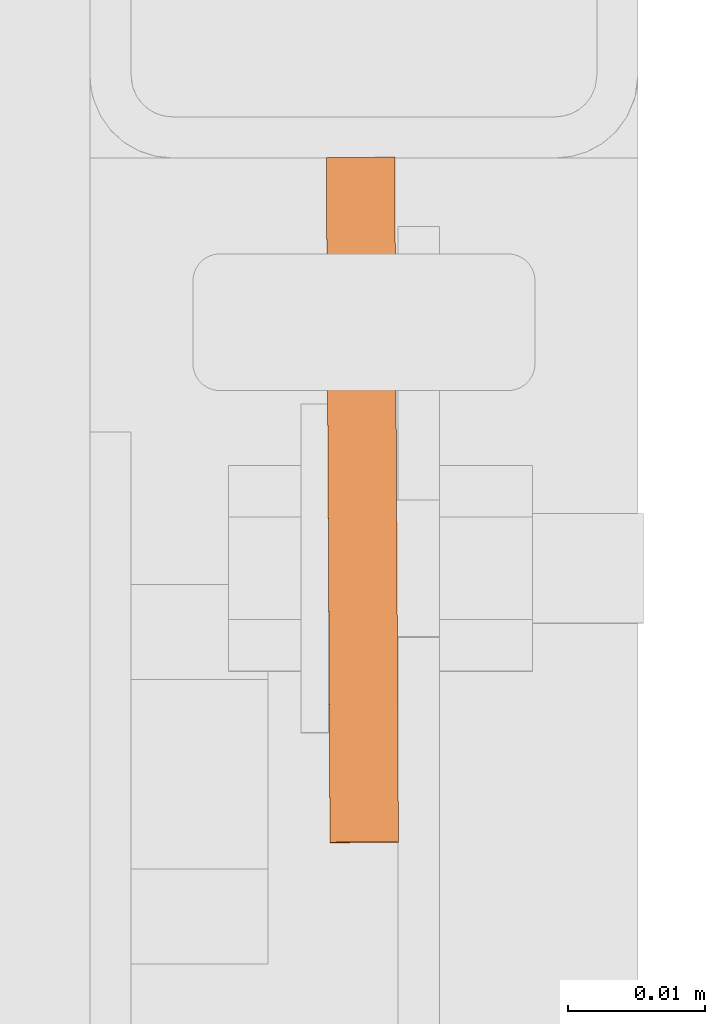
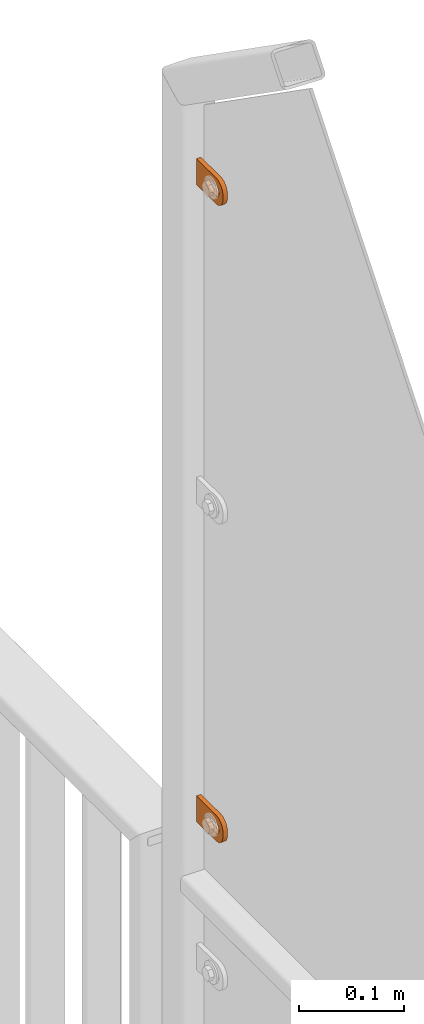
# One storey, part 148 of 156: 2 proxies, 1 element without a shape of its own.
"""IFC2X3 building model written with IfcOpenShell, lengths in millimetres."""

import ifcopenshell
import ifcopenshell.guid

model = None  # the IFC model being written
_history = None  # IfcOwnerHistory: only IFC2X3 demands one
_inside = {}  # id of a spatial element -> (the spatial element, [elements in it])
_under = {}  # id of a project, library or spatial element -> (it, [spatial elements below it])
_declared = {}  # id of a project -> (the project, [libraries it declares])
_typed = {}  # id of a type object -> (the type object, [elements of that type])
_made_of = {}  # id of a material, layer set ... -> (it, [elements and type objects made of it])


def new_model(schema):
    """Start an empty IFC model of exactly this schema.

    Asked for "IFC4X3", IfcOpenShell would pick the latest addendum, in which some entities
    have other attributes; the version numbers below select the first issue.
    IFC2X3 requires an IfcOwnerHistory on every rooted entity: one is made here for all.
    """
    global model, _history
    if schema == "IFC4X3":
        model = ifcopenshell.file(schema_version=(4, 3, 0, 0))
    else:
        model = ifcopenshell.file(schema=schema)
    _inside.clear()
    _under.clear()
    _declared.clear()
    _typed.clear()
    _made_of.clear()
    _history = None
    if model.schema == "IFC2X3":
        org = make("IfcOrganization", Name="unknown")
        user = make(
            "IfcPersonAndOrganization",
            ThePerson=make("IfcPerson", FamilyName="unknown"),
            TheOrganization=org,
        )
        app = make(
            "IfcApplication",
            ApplicationDeveloper=org,
            Version="unknown",
            ApplicationFullName="unknown",
            ApplicationIdentifier="unknown",
        )
        _history = make(
            "IfcOwnerHistory",
            OwningUser=user,
            OwningApplication=app,
            ChangeAction="ADDED",
            CreationDate=0,
        )
    return model


def make(cls, **values):
    """One entity of the class cls with the attributes given. An attribute that is None is left unset."""
    return model.create_entity(
        cls, **{name: value for name, value in values.items() if value is not None}
    )


def rooted(cls, **values):
    """An entity with a GlobalId (a new one), such as an element, a storey or a relation."""
    return make(cls, GlobalId=ifcopenshell.guid.new(), OwnerHistory=_history, **values)


def si_unit(unit_type, name, prefix=None):
    """IfcSIUnit, for example si_unit("LENGTHUNIT", "METRE", prefix="MILLI")."""
    return make("IfcSIUnit", UnitType=unit_type, Prefix=prefix, Name=name)


def assignment(units):
    """IfcUnitAssignment: the units of a project."""
    return None if units is None else make("IfcUnitAssignment", Units=units)


def point(xyz):
    """IfcCartesianPoint."""
    return None if xyz is None else make("IfcCartesianPoint", Coordinates=xyz)


def direction(xyz):
    """IfcDirection."""
    return None if xyz is None else make("IfcDirection", DirectionRatios=xyz)


def frame(location, z_axis=None, x_axis=None):
    """IfcAxis2Placement3D, a coordinate frame: its origin and axes. An axis left out is left unset."""
    return make(
        "IfcAxis2Placement3D",
        Location=point(location),
        Axis=direction(z_axis),
        RefDirection=direction(x_axis),
    )


def origin_with_axes():
    """The frame at (0, 0, 0) with the z axis (0, 0, 1) and the x axis (1, 0, 0) written out."""
    return frame((0.0, 0.0, 0.0), z_axis=(0.0, 0.0, 1.0), x_axis=(1.0, 0.0, 0.0))


def place(relative_to, where):
    """IfcLocalPlacement: puts the frame where relative to a parent placement (None: the world)."""
    return make(
        "IfcLocalPlacement", PlacementRelTo=relative_to, RelativePlacement=where
    )


def context(
    kind, dimensions, precision=None, world=None, true_north=None, identifier=None
):
    """IfcGeometricRepresentationContext, for example the 3D "Model" context."""
    return make(
        "IfcGeometricRepresentationContext",
        ContextIdentifier=identifier,
        ContextType=kind,
        CoordinateSpaceDimension=dimensions,
        Precision=precision,
        WorldCoordinateSystem=world,
        TrueNorth=true_north,
    )


def subcontext(parent, identifier, kind, view, scale=None):
    """IfcGeometricRepresentationSubContext, for example "Body" below "Model"."""
    return make(
        "IfcGeometricRepresentationSubContext",
        ContextIdentifier=identifier,
        ContextType=kind,
        ParentContext=parent,
        TargetScale=scale,
        TargetView=view,
    )


def project(units=None, contexts=None):
    """IfcProject with its units and contexts."""
    return rooted(
        "IfcProject",
        Name="project",
        RepresentationContexts=contexts,
        UnitsInContext=assignment(units),
    )


def spatial(cls, under=None, at=None, **own):
    """A site, building, storey or space (cls), placed at a placement, below another one or the project."""
    s = rooted(cls, ObjectPlacement=at, **own)
    if under is not None:
        _under.setdefault(under.id(), (under, []))[1].append(s)
    return s


def faces_of(points, faces, orient=None, outer=None):
    """IfcFace entities. A face is a list of loops; a loop is a list of indices into points, from 0.

    orient and outer hold one flag for each loop. By default every Orientation is true, the
    first loop of a face is its IfcFaceOuterBound and the others are IfcFaceBound.
    """
    made = []
    for i, loops in enumerate(faces):
        bounds = []
        for j, loop in enumerate(loops):
            is_outer = j == 0 if outer is None else outer[i][j]
            bounds.append(
                make(
                    "IfcFaceOuterBound" if is_outer else "IfcFaceBound",
                    Bound=make("IfcPolyLoop", Polygon=[points[k] for k in loop]),
                    Orientation=True if orient is None else orient[i][j],
                )
            )
        made.append(make("IfcFace", Bounds=bounds))
    return made


def faceted_brep(points, faces, orient=None, outer=None, voids=None):
    """IfcFacetedBrep: a solid bounded by flat faces; with voids (closed shells), ...WithVoids."""
    shared = [point(p) for p in points]
    hull = make("IfcClosedShell", CfsFaces=faces_of(shared, faces, orient, outer))
    if voids is None:
        return make("IfcFacetedBrep", Outer=hull)
    return make(
        "IfcFacetedBrepWithVoids",
        Outer=hull,
        Voids=[
            make(cls, CfsFaces=faces_of(shared, fs, o, b)) for cls, fs, o, b in voids
        ],
    )


def shape(context_of_items, identifier, shape_type, items):
    """IfcShapeRepresentation: the items that make up one representation, for example the "Body"."""
    return make(
        "IfcShapeRepresentation",
        ContextOfItems=context_of_items,
        RepresentationIdentifier=identifier,
        RepresentationType=shape_type,
        Items=items,
    )


def material(Name=None, Category=None):
    """IfcMaterial."""
    return make("IfcMaterial", Name=Name, Category=Category)


def made_of(thing, what):
    """Note that an element or type object is made of a material, layer set ...; save() writes the relation."""
    if what is not None:
        _made_of.setdefault(what.id(), (what, []))[1].append(thing)
    return thing


def type_object(cls, material=None, **own):
    """A type object (cls), such as IfcWallType, which elements share."""
    return made_of(rooted(cls, **own), material)


def element(
    cls,
    number,
    at=None,
    inside=None,
    cuts=None,
    type_object=None,
    material=None,
    context=None,
    identifier="Body",
    shape_type=None,
    held_by="IfcProductDefinitionShape",
    body=None,
    shapes=None,
    **own,
):
    """One element of the class cls, such as IfcWall. Its Tag is "e" and its number.

    at: its placement. inside: the storey or other place that contains it. cuts: it is an
    opening in that element (IfcRelVoidsElement). A single representation is given by context,
    identifier, shape_type and body (its items); several are given by shapes. held_by: the class
    of the entity that holds the representations. save() writes the other relations.
    """
    e = rooted(cls, Tag="e%d" % number, ObjectPlacement=at, **own)
    if body is not None:
        shapes = [shape(context, identifier, shape_type, body)]
    if shapes is not None:
        e.Representation = make(held_by, Representations=shapes)
    if inside is not None:
        _inside.setdefault(inside.id(), (inside, []))[1].append(e)
    if cuts is not None:
        rooted(
            "IfcRelVoidsElement", RelatingBuildingElement=cuts, RelatedOpeningElement=e
        )
    if type_object is not None:
        _typed.setdefault(type_object.id(), (type_object, []))[1].append(e)
    return made_of(e, material)


def aggregate(whole, parts):
    """IfcRelAggregates: a whole, such as a stair, and the parts it consists of."""
    return rooted("IfcRelAggregates", RelatingObject=whole, RelatedObjects=parts)


def save(model, path):
    """Write the relations noted so far, then the file.

    IfcRelAggregates (storeys below a building ...), IfcRelContainedInSpatialStructure (elements
    in a storey), IfcRelDefinesByType, IfcRelAssociatesMaterial and IfcRelDeclares: one each for
    every whole, place, type object, material and project.
    """
    for whole, parts in _under.values():
        aggregate(whole, parts)
    for where, things in _inside.values():
        rooted(
            "IfcRelContainedInSpatialStructure",
            RelatedElements=things,
            RelatingStructure=where,
        )
    for kind, things in _typed.values():
        rooted("IfcRelDefinesByType", RelatedObjects=things, RelatingType=kind)
    for what, things in _made_of.values():
        rooted("IfcRelAssociatesMaterial", RelatedObjects=things, RelatingMaterial=what)
    for by, libraries in _declared.values():
        rooted("IfcRelDeclares", RelatingContext=by, RelatedDefinitions=libraries)
    model.write(path)


model = new_model("IFC2X3")

# Units and contexts
model_context = context("Model", 3, precision=1e-05, world=origin_with_axes())
body_context = subcontext(model_context, "Body", "Model", "MODEL_VIEW")
ifc_project = project(units=[si_unit("LENGTHUNIT", "METRE", prefix="MILLI"), si_unit("AREAUNIT", "SQUARE_METRE"), si_unit("VOLUMEUNIT", "CUBIC_METRE"), si_unit("MASSUNIT", "GRAM", prefix="KILO"), si_unit("TIMEUNIT", "SECOND"), si_unit("PLANEANGLEUNIT", "RADIAN"), si_unit("SOLIDANGLEUNIT", "STERADIAN"), si_unit("THERMODYNAMICTEMPERATUREUNIT", "DEGREE_CELSIUS"), si_unit("LUMINOUSINTENSITYUNIT", "LUMEN")], contexts=[model_context])

# Site, building, storey
site_placement = place(None, origin_with_axes())
site = spatial("IfcSite", under=ifc_project, at=site_placement, CompositionType="ELEMENT")
building_placement = place(site_placement, origin_with_axes())
building = spatial("IfcBuilding", under=site, at=building_placement, Name="Undefined", CompositionType="ELEMENT")
storey_placement = place(building_placement, origin_with_axes())
storey = spatial("IfcBuildingStorey", under=building, at=storey_placement, Name="Undefined", CompositionType="ELEMENT", Elevation=0.0)

# Assembly, proxies
assembly_placement = place(storey_placement, origin_with_axes())
assembly = element("IfcElementAssembly", 1, at=assembly_placement, inside=storey, AssemblyPlace="NOTDEFINED", PredefinedType="RIGID_FRAME")
ifc_material = material(Name="STEEL/S235JR")
building_element_proxy_type = type_object("IfcBuildingElementProxyType", Name="50", PredefinedType="NOTDEFINED")
proxy_1_placement = place(assembly_placement, frame((36514.7461242676, 20958.0466306098, 4811.41994708695), z_axis=(-0.999985556002151, -0.00537473600001249, 0.0), x_axis=(0.00537473600001187, -0.999985556002151, 1.19999999540802e-08)))
proxy_1 = element("IfcBuildingElementProxy", 2, at=proxy_1_placement, type_object=building_element_proxy_type, material=ifc_material, ObjectType="50", CompositionType="ELEMENT", context=body_context, shape_type="Brep", body=[
    faceted_brep([(37.0000004768226, -5.50000056624776, -2.49999994410609), (23.0000000446889, -5.50000056624594, -2.49999994410973), (23.0000000446889, -5.50000056624594, 2.49999994413156), (37.000000476819, -5.50000056624776, 2.49999994413338), (21.9270028173814, -5.39431966841403, -2.49999994410973), (21.9270028173778, -5.39431966841403, 2.49999994412792), (20.895240828384, -5.0813375413436, -2.49999994411155), (20.895240828384, -5.0813375413436, 2.49999994412974), (19.9443642049955, -4.5730831474084, -2.49999994410973), (19.9443642049919, -4.5730831474084, 2.49999994412792), (19.1109124571012, -3.88908818364325, -2.49999994411155), (19.1109124571012, -3.88908818364325, 2.49999994412792), (18.4269174933361, -3.05563643574806, -2.49999994411155), (18.4269174933361, -3.05563643574806, 2.4999999441261), (17.9186630994009, -2.1047579497108, -2.49999994411155), (17.9186630994009, -2.1047579497108, 2.49999994412428), (17.6056809723377, -1.07299596071425, -2.49999994411337), (17.6056809723341, -1.07299596071425, 2.4999999441261), (17.5000000745022, 3.3527521736687e-07, -2.49999994411519), (17.5000000745058, 3.3527521736687e-07, 2.49999994412428), (17.6056809723377, 1.07299663126287, -2.49999994411701), (17.6056809723377, 1.07299663126287, 2.49999994412428), (17.9186630994154, 2.10475862026124, -2.49999994411701), (17.9186630994118, 2.10475862026124, 2.49999994412246), (18.426917493347, 3.05563617497592, -2.49999994411701), (18.426917493347, 3.05563617497592, 2.49999994412246), (19.1109124571158, 3.88908699154672, -2.49999994411883), (19.1109124571121, 3.88908699154672, 2.49999994412065), (19.9443642050101, 4.57308288663444, -2.49999994411701), (19.9443642050064, 4.57308288663444, 2.49999994412065), (20.8952408283985, 5.08133728056964, -2.49999994411883), (20.8952408283985, 5.08133728056964, 2.49999994412065), (21.9270028173996, 5.39431940764007, -2.49999994411883), (21.927002817396, 5.39431940764007, 2.49999994412065), (23.0000000447108, 5.50000030547199, -2.49999994411883), (23.0000000447071, 5.50000030547199, 2.49999994412246), (37.0000004768408, 5.50000030547017, -2.49999994411519), (37.0000004768408, 5.50000030547017, 2.49999994412428), (38.0729958415031, 5.39431940763825, -2.49999994411519), (38.0729958414995, 5.39431940763825, 2.49999994412428), (39.1047596931458, 5.08133728056691, -2.49999994411337), (39.1047596931421, 5.08133728056691, 2.49999994412428), (40.0556363165415, 4.57308288663171, -2.49999994411519), (40.0556363165379, 4.57308288663171, 2.4999999441261), (40.8890880644285, 3.8890869915449, -2.49999994411337), (40.8890880644285, 3.8890869915449, 2.49999994412792), (41.5730811655449, 3.05563617497228, -2.49999994411337), (41.5730811655449, 3.05563617497228, 2.4999999441261), (42.0813374221252, 2.1047586202576, -2.49999994411155), (42.0813374221252, 2.1047586202576, 2.49999994412792), (42.3943176865469, 1.07299663126014, -2.49999994410973), (42.3943176865469, 1.07299663126014, 2.49999994412974), (42.5000004470239, 3.35271579388063e-07, -2.49999994410973), (42.5000004470276, 3.35271579388063e-07, 2.49999994412974), (42.3943176865469, -1.07299596071698, -2.49999994410791), (42.3943176865432, -1.07299596071698, 2.49999994413156), (42.0813374221179, -2.10475794971444, -2.49999994410791), (42.0813374221143, -2.10475794971444, 2.49999994413338), (41.5730811655376, -3.05563643575169, -2.49999994410791), (41.5730811655339, -3.05563643575169, 2.49999994413156), (40.8890880644176, -3.88908818364507, -2.49999994410609), (40.889088064414, -3.88908818364507, 2.49999994413338), (40.0556363165233, -4.57308314741113, -2.49999994410791), (40.0556363165233, -4.57308314741113, 2.49999994413338), (39.1047596931276, -5.08133754134633, -2.49999994410609), (39.1047596931276, -5.08133754134633, 2.49999994413338), (38.072995841485, -5.39431966841585, -2.49999994410609), (38.072995841485, -5.39431966841585, 2.49999994413156), (37.0000004768044, -14.9999993294514, 2.49999994414065), (39.5361743867034, -14.7502093017147, 2.49999994414065), (41.9748835265273, -14.0104337036646, 2.49999994414065), (44.222414493528, -12.8091058135078, 2.49999994414247), (46.192388981548, -11.1923875659759, 2.49999994413884), (47.809105366443, -9.22241307795593, 2.49999994413884), (49.010433256597, -6.97488397360394, 2.49999994413702), (49.7502088546535, -4.53617483378002, 2.49999994413338), (50.0000007450435, -2.00000092387745, 2.49999994413338), (50.0000007450471, 1.99999973177364, 2.49999994412974), (49.7502088546717, 4.53617457299879, 2.4999999441261), (49.0104332566261, 6.97488464414528, 2.4999999441261), (47.8091053664721, 9.2224128171747, 2.49999994412428), (46.192388981588, 11.1923882365172, 2.49999994412065), (44.2224144935717, 12.8091048542365, 2.49999994411883), (41.9748835265782, 14.0104339085483, 2.49999994411883), (39.5361743867543, 14.7502086334816, 2.49999994411701), (37.0000004768553, 14.9999999999964, 2.49999994411519), (2.91038304567337e-11, 15.0000000000009, 2.49999994410791), (-2.18278728425503e-11, -14.9999993294468, 2.49999994413338), (3.27418092638254e-11, 15.0000000000009, -2.49999994413156), (-2.18278728425503e-11, -14.9999993294468, -2.49999994410791), (37.0000004768008, -14.9999993294514, -2.49999994409882), (39.5361743867034, -14.7502093017147, -2.49999994409882), (41.9748835265309, -14.0104337036646, -2.499999944097), (44.222414493528, -12.8091058135078, -2.49999994409882), (46.1923889815516, -11.1923875659759, -2.49999994409882), (47.8091053664393, -9.22241307795593, -2.49999994410064), (49.0104332566007, -6.97488397360394, -2.49999994410246), (49.7502088546535, -4.53617483378002, -2.49999994410609), (50.0000007450435, -2.00000092387745, -2.49999994410609), (50.0000007450508, 1.99999973177364, -2.49999994410973), (49.750208854668, 4.53617457299879, -2.49999994411155), (49.0104332566261, 6.97488464414528, -2.49999994411337), (47.8091053664721, 9.2224128171747, -2.49999994411519), (46.1923889815916, 11.1923882365172, -2.49999994411883), (44.2224144935717, 12.8091048542365, -2.49999994411883), (41.9748835265782, 14.0104339085483, -2.49999994412065), (39.5361743867579, 14.7502086334816, -2.49999994412246), (37.000000476859, 14.9999999999964, -2.49999994412428)], [[[0, 1, 2, 3]], [[1, 4, 5, 2]], [[4, 6, 7, 5]], [[6, 8, 9, 7]], [[8, 10, 11, 9]], [[10, 12, 13, 11]], [[12, 14, 15, 13]], [[14, 16, 17, 15]], [[16, 18, 19, 17]], [[18, 20, 21, 19]], [[20, 22, 23, 21]], [[22, 24, 25, 23]], [[24, 26, 27, 25]], [[26, 28, 29, 27]], [[28, 30, 31, 29]], [[30, 32, 33, 31]], [[32, 34, 35, 33]], [[34, 36, 37, 35]], [[36, 38, 39, 37]], [[38, 40, 41, 39]], [[40, 42, 43, 41]], [[42, 44, 45, 43]], [[44, 46, 47, 45]], [[46, 48, 49, 47]], [[48, 50, 51, 49]], [[50, 52, 53, 51]], [[52, 54, 55, 53]], [[54, 56, 57, 55]], [[56, 58, 59, 57]], [[58, 60, 61, 59]], [[60, 62, 63, 61]], [[62, 64, 65, 63]], [[64, 66, 67, 65]], [[66, 0, 3, 67]], [[68, 69, 70, 71, 72, 73, 74, 75, 76, 77, 78, 79, 80, 81, 82, 83, 84, 85, 86, 87], [5, 7, 9, 11, 13, 15, 17, 19, 21, 23, 25, 27, 29, 31, 33, 35, 37, 39, 41, 43, 45, 47, 49, 51, 53, 55, 57, 59, 61, 63, 65, 67, 3, 2]], [[86, 88, 89, 87]], [[87, 89, 90, 68]], [[68, 90, 91, 69]], [[69, 91, 92, 70]], [[70, 92, 93, 71]], [[71, 93, 94, 72]], [[72, 94, 95, 73]], [[73, 95, 96, 74]], [[74, 96, 97, 75]], [[75, 97, 98, 76]], [[76, 98, 99, 77]], [[77, 99, 100, 78]], [[78, 100, 101, 79]], [[79, 101, 102, 80]], [[80, 102, 103, 81]], [[81, 103, 104, 82]], [[82, 104, 105, 83]], [[83, 105, 106, 84]], [[84, 106, 107, 85]], [[85, 107, 88, 86]], [[105, 104, 103, 102, 101, 100, 99, 98, 97, 96, 95, 94, 93, 92, 91, 90, 89, 88, 107, 106], [60, 58, 56, 54, 52, 50, 48, 46, 44, 42, 40, 38, 36, 34, 32, 30, 28, 26, 24, 22, 20, 18, 16, 14, 12, 10, 8, 6, 4, 1, 0, 66, 64, 62]]]),
])
proxy_2_placement = place(assembly_placement, frame((36514.7461242676, 20958.0046023384, 4072.79352643115), z_axis=(-0.999985556002151, -0.00537473600001249, 0.0), x_axis=(0.00537473600001187, -0.999985556002151, 1.19999999540802e-08)))
proxy_2 = element("IfcBuildingElementProxy", 3, at=proxy_2_placement, type_object=building_element_proxy_type, material=ifc_material, ObjectType="50", CompositionType="ELEMENT", context=body_context, shape_type="Brep", body=[
    faceted_brep([(37.0000004768226, -5.50000056624776, -2.49999994410609), (23.0000000446889, -5.50000056624594, -2.49999994410973), (23.0000000446889, -5.50000056624594, 2.49999994413156), (37.000000476819, -5.50000056624776, 2.49999994413338), (21.9270028173814, -5.39431966841403, -2.49999994410973), (21.9270028173778, -5.39431966841403, 2.49999994412792), (20.895240828384, -5.0813375413436, -2.49999994411155), (20.895240828384, -5.0813375413436, 2.49999994412974), (19.9443642049955, -4.5730831474084, -2.49999994410973), (19.9443642049919, -4.5730831474084, 2.49999994412792), (19.1109124571012, -3.88908818364325, -2.49999994411155), (19.1109124571012, -3.88908818364325, 2.49999994412792), (18.4269174933361, -3.05563643574806, -2.49999994411155), (18.4269174933361, -3.05563643574806, 2.4999999441261), (17.9186630994009, -2.1047579497108, -2.49999994411155), (17.9186630994009, -2.1047579497108, 2.49999994412428), (17.6056809723377, -1.07299596071425, -2.49999994411337), (17.6056809723341, -1.07299596071425, 2.4999999441261), (17.5000000745022, 3.3527521736687e-07, -2.49999994411519), (17.5000000745058, 3.3527521736687e-07, 2.49999994412428), (17.6056809723377, 1.07299663126287, -2.49999994411701), (17.6056809723377, 1.07299663126287, 2.49999994412428), (17.9186630994154, 2.10475862026124, -2.49999994411701), (17.9186630994118, 2.10475862026124, 2.49999994412246), (18.426917493347, 3.05563617497592, -2.49999994411701), (18.426917493347, 3.05563617497592, 2.49999994412246), (19.1109124571158, 3.88908699154672, -2.49999994411883), (19.1109124571121, 3.88908699154672, 2.49999994412065), (19.9443642050101, 4.57308288663444, -2.49999994411701), (19.9443642050064, 4.57308288663444, 2.49999994412065), (20.8952408283985, 5.08133728056964, -2.49999994411883), (20.8952408283985, 5.08133728056964, 2.49999994412065), (21.9270028173996, 5.39431940764007, -2.49999994411883), (21.927002817396, 5.39431940764007, 2.49999994412065), (23.0000000447108, 5.50000030547199, -2.49999994411883), (23.0000000447071, 5.50000030547199, 2.49999994412246), (37.0000004768408, 5.50000030547017, -2.49999994411519), (37.0000004768408, 5.50000030547017, 2.49999994412428), (38.0729958415031, 5.39431940763825, -2.49999994411519), (38.0729958414995, 5.39431940763825, 2.49999994412428), (39.1047596931458, 5.08133728056691, -2.49999994411337), (39.1047596931421, 5.08133728056691, 2.49999994412428), (40.0556363165415, 4.57308288663171, -2.49999994411519), (40.0556363165379, 4.57308288663171, 2.4999999441261), (40.8890880644285, 3.8890869915449, -2.49999994411337), (40.8890880644285, 3.8890869915449, 2.49999994412792), (41.5730811655449, 3.05563617497228, -2.49999994411337), (41.5730811655449, 3.05563617497228, 2.4999999441261), (42.0813374221252, 2.1047586202576, -2.49999994411155), (42.0813374221252, 2.1047586202576, 2.49999994412792), (42.3943176865469, 1.07299663126014, -2.49999994410973), (42.3943176865469, 1.07299663126014, 2.49999994412974), (42.5000004470239, 3.35271579388063e-07, -2.49999994410973), (42.5000004470276, 3.35271579388063e-07, 2.49999994412974), (42.3943176865469, -1.07299596071698, -2.49999994410791), (42.3943176865432, -1.07299596071698, 2.49999994413156), (42.0813374221179, -2.10475794971444, -2.49999994410791), (42.0813374221143, -2.10475794971444, 2.49999994413338), (41.5730811655376, -3.05563643575169, -2.49999994410791), (41.5730811655339, -3.05563643575169, 2.49999994413156), (40.8890880644176, -3.88908818364507, -2.49999994410609), (40.889088064414, -3.88908818364507, 2.49999994413338), (40.0556363165233, -4.57308314741113, -2.49999994410791), (40.0556363165233, -4.57308314741113, 2.49999994413338), (39.1047596931276, -5.08133754134633, -2.49999994410609), (39.1047596931276, -5.08133754134633, 2.49999994413338), (38.072995841485, -5.39431966841585, -2.49999994410609), (38.072995841485, -5.39431966841585, 2.49999994413156), (37.0000004768044, -14.9999993294514, 2.49999994414065), (39.5361743867034, -14.7502093017147, 2.49999994414065), (41.9748835265273, -14.0104337036646, 2.49999994414065), (44.222414493528, -12.8091058135078, 2.49999994414247), (46.192388981548, -11.1923875659759, 2.49999994413884), (47.809105366443, -9.22241307795593, 2.49999994413884), (49.010433256597, -6.97488397360394, 2.49999994413702), (49.7502088546535, -4.53617483378002, 2.49999994413338), (50.0000007450435, -2.00000092387745, 2.49999994413338), (50.0000007450471, 1.99999973177364, 2.49999994412974), (49.7502088546717, 4.53617457299879, 2.4999999441261), (49.0104332566261, 6.97488464414528, 2.4999999441261), (47.8091053664721, 9.2224128171747, 2.49999994412428), (46.192388981588, 11.1923882365172, 2.49999994412065), (44.2224144935717, 12.8091048542365, 2.49999994411883), (41.9748835265782, 14.0104339085483, 2.49999994411883), (39.5361743867543, 14.7502086334816, 2.49999994411701), (37.0000004768553, 14.9999999999964, 2.49999994411519), (2.91038304567337e-11, 15.0000000000009, 2.49999994410791), (-2.18278728425503e-11, -14.9999993294468, 2.49999994413338), (3.27418092638254e-11, 15.0000000000009, -2.49999994413156), (-2.18278728425503e-11, -14.9999993294468, -2.49999994410791), (37.0000004768008, -14.9999993294514, -2.49999994409882), (39.5361743867034, -14.7502093017147, -2.49999994409882), (41.9748835265309, -14.0104337036646, -2.499999944097), (44.222414493528, -12.8091058135078, -2.49999994409882), (46.1923889815516, -11.1923875659759, -2.49999994409882), (47.8091053664393, -9.22241307795593, -2.49999994410064), (49.0104332566007, -6.97488397360394, -2.49999994410246), (49.7502088546535, -4.53617483378002, -2.49999994410609), (50.0000007450435, -2.00000092387745, -2.49999994410609), (50.0000007450508, 1.99999973177364, -2.49999994410973), (49.750208854668, 4.53617457299879, -2.49999994411155), (49.0104332566261, 6.97488464414528, -2.49999994411337), (47.8091053664721, 9.2224128171747, -2.49999994411519), (46.1923889815916, 11.1923882365172, -2.49999994411883), (44.2224144935717, 12.8091048542365, -2.49999994411883), (41.9748835265782, 14.0104339085483, -2.49999994412065), (39.5361743867579, 14.7502086334816, -2.49999994412246), (37.000000476859, 14.9999999999964, -2.49999994412428)], [[[0, 1, 2, 3]], [[1, 4, 5, 2]], [[4, 6, 7, 5]], [[6, 8, 9, 7]], [[8, 10, 11, 9]], [[10, 12, 13, 11]], [[12, 14, 15, 13]], [[14, 16, 17, 15]], [[16, 18, 19, 17]], [[18, 20, 21, 19]], [[20, 22, 23, 21]], [[22, 24, 25, 23]], [[24, 26, 27, 25]], [[26, 28, 29, 27]], [[28, 30, 31, 29]], [[30, 32, 33, 31]], [[32, 34, 35, 33]], [[34, 36, 37, 35]], [[36, 38, 39, 37]], [[38, 40, 41, 39]], [[40, 42, 43, 41]], [[42, 44, 45, 43]], [[44, 46, 47, 45]], [[46, 48, 49, 47]], [[48, 50, 51, 49]], [[50, 52, 53, 51]], [[52, 54, 55, 53]], [[54, 56, 57, 55]], [[56, 58, 59, 57]], [[58, 60, 61, 59]], [[60, 62, 63, 61]], [[62, 64, 65, 63]], [[64, 66, 67, 65]], [[66, 0, 3, 67]], [[68, 69, 70, 71, 72, 73, 74, 75, 76, 77, 78, 79, 80, 81, 82, 83, 84, 85, 86, 87], [5, 7, 9, 11, 13, 15, 17, 19, 21, 23, 25, 27, 29, 31, 33, 35, 37, 39, 41, 43, 45, 47, 49, 51, 53, 55, 57, 59, 61, 63, 65, 67, 3, 2]], [[86, 88, 89, 87]], [[87, 89, 90, 68]], [[68, 90, 91, 69]], [[69, 91, 92, 70]], [[70, 92, 93, 71]], [[71, 93, 94, 72]], [[72, 94, 95, 73]], [[73, 95, 96, 74]], [[74, 96, 97, 75]], [[75, 97, 98, 76]], [[76, 98, 99, 77]], [[77, 99, 100, 78]], [[78, 100, 101, 79]], [[79, 101, 102, 80]], [[80, 102, 103, 81]], [[81, 103, 104, 82]], [[82, 104, 105, 83]], [[83, 105, 106, 84]], [[84, 106, 107, 85]], [[85, 107, 88, 86]], [[105, 104, 103, 102, 101, 100, 99, 98, 97, 96, 95, 94, 93, 92, 91, 90, 89, 88, 107, 106], [60, 58, 56, 54, 52, 50, 48, 46, 44, 42, 40, 38, 36, 34, 32, 30, 28, 26, 24, 22, 20, 18, 16, 14, 12, 10, 8, 6, 4, 1, 0, 66, 64, 62]]]),
])
aggregate(assembly, [proxy_1, proxy_2])

save(model, "model.ifc")
